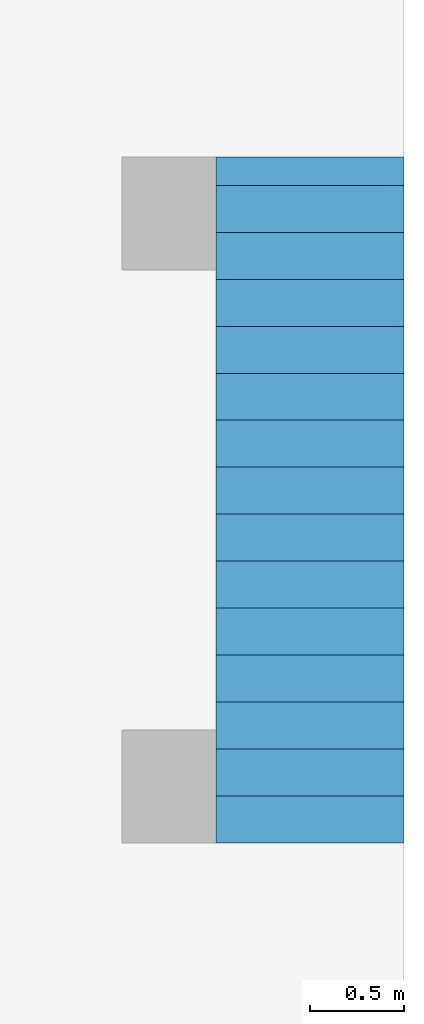
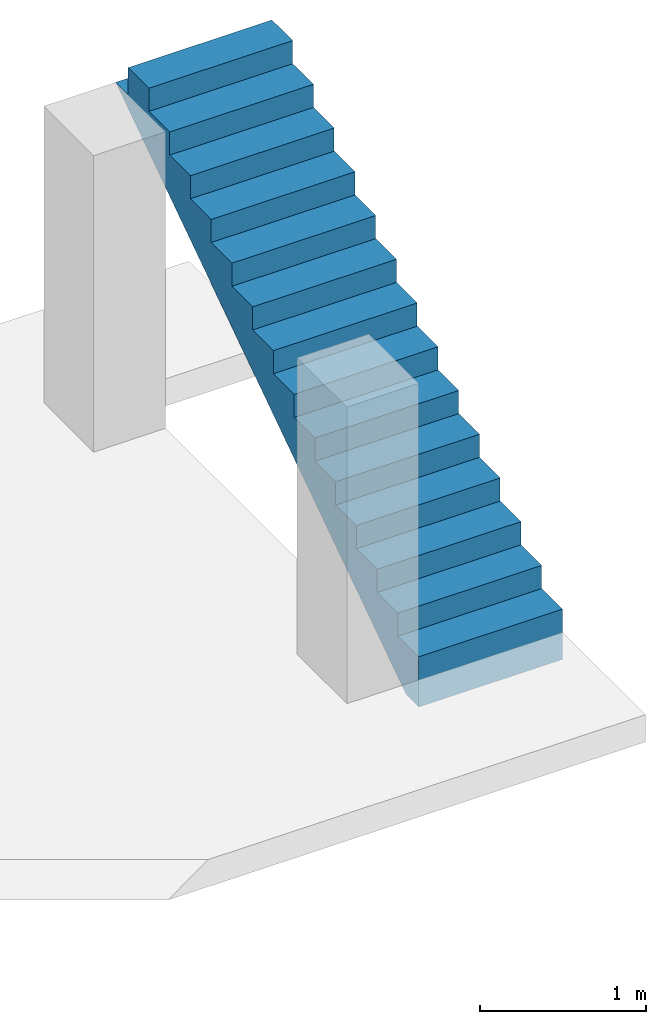
# One storey, part 2 of 2: 1 stair flight.
"""IFC4 building model written with IfcOpenShell, lengths in millimetres."""

from ifc_helpers import new_model, entity, si_unit, converted_unit, frame, origin_with_axes, origin_2d_with_axis, place, context, subcontext, project, spatial, polygons, element, save


model = new_model("IFC4")

# Units and contexts
model_context = context("Model", 3, precision=1e-05, world=origin_with_axes())
plan_context = context("Plan", 2, precision=1e-05, world=origin_2d_with_axis())
body_context = subcontext(model_context, "Body", "Model", "MODEL_VIEW")
ifc_project = project(units=[si_unit("VOLUMEUNIT", "CUBIC_METRE", prefix="MILLI"), si_unit("LENGTHUNIT", "METRE", prefix="MILLI"), converted_unit("PLANEANGLEUNIT", "degree", entity("IfcReal", 0.0174532925199433), si_unit("PLANEANGLEUNIT", "RADIAN"), dimensions=[0, 0, 0, 0, 0, 0, 0]), si_unit("AREAUNIT", "SQUARE_METRE", prefix="MILLI")], contexts=[model_context, plan_context])

# Site, building, storey
site_placement = place(None, origin_with_axes())
site = spatial("IfcSite", under=ifc_project, at=site_placement)
building_placement = place(site_placement, origin_with_axes())
building = spatial("IfcBuilding", under=site, at=building_placement, Name="Building")
storey_placement = place(building_placement, frame((0.0, 0.0, 2380.00011444092), z_axis=(0.0, 0.0, 1.0), x_axis=(1.0, 0.0, 0.0)))
storey = spatial("IfcBuildingStorey", under=building, at=storey_placement, Name="1st Floor")

# Stair flight
stair_flight_placement = place(storey_placement, frame((5000.0, 1000.0, 0.0), z_axis=(0.0, 0.0, 1.0), x_axis=(-4.37113882867379e-08, 1.0, 0.0)))
element("IfcStairFlight", 1, at=stair_flight_placement, inside=storey, Name="Stair", NumberOfRisers=7, NumberOfTreads=6, PredefinedType="STRAIGHT", RiserHeight=142.857142857143, TreadLength=250.0, context=body_context, shape_type="Tessellation", body=[
    polygons([(0.0, 0.0, 0.0), (0.0, 0.0, 169.999984741211), (249.999984741211, 0.0, 169.999984741211), (249.999984741211, 0.0, 339.999969482422), (499.999969482422, 0.0, 339.999969482422), (499.999969482422, 0.0, 509.999969482422), (749.999938964844, 0.0, 509.999969482422), (749.999938964844, 0.0, 679.999938964844), (999.999938964844, 0.0, 679.999938964844), (999.999938964844, 0.0, 850.0), (1249.99987792969, 0.0, 850.0), (1249.99987792969, 0.0, 1019.99993896484), (1499.99987792969, 0.0, 1019.99993896484), (1499.99987792969, 0.0, 1190.0), (1749.99987792969, 0.0, 1190.0), (1749.99987792969, 0.0, 1359.99987792969), (1999.99987792969, 0.0, 1359.99987792969), (1999.99987792969, 0.0, 1529.99987792969), (2249.99975585938, 0.0, 1529.99987792969), (2249.99975585938, 0.0, 1700.0), (2499.99975585938, 0.0, 1700.0), (2499.99975585938, 0.0, 1869.99987792969), (2749.99975585938, 0.0, 1869.99987792969), (2749.99975585938, 0.0, 2039.99987792969), (2999.99975585938, 0.0, 2039.99987792969), (2999.99975585938, 0.0, 2210.0), (3249.99975585938, 0.0, 2210.0), (3249.99975585938, 0.0, 2380.0), (3499.99975585938, 0.0, 2380.0), (3499.99975585938, 0.0, 2180.0), (3650.47680664062, 0.0, 2180.0), (150.476959228516, 0.0, -199.999984741211), (0.0, 0.0, -199.999984741211), (0.0, 999.999938964844, 169.999984741211), (249.999984741211, 999.999938964844, 169.999984741211), (249.999984741211, 999.999938964844, 339.999969482422), (499.999969482422, 999.999938964844, 339.999969482422), (499.999969482422, 999.999938964844, 509.999969482422), (749.999938964844, 999.999938964844, 509.999969482422), (749.999938964844, 999.999938964844, 679.999938964844), (999.999938964844, 999.999938964844, 679.999938964844), (999.999938964844, 999.999938964844, 850.0), (1249.99987792969, 999.999938964844, 850.0), (1249.99987792969, 999.999938964844, 1019.99993896484), (1499.99987792969, 999.999938964844, 1019.99993896484), (1499.99987792969, 999.999938964844, 1190.0), (1749.99987792969, 999.999938964844, 1190.0), (1749.99987792969, 999.999938964844, 1359.99987792969), (1999.99987792969, 999.999938964844, 1359.99987792969), (1999.99987792969, 999.999938964844, 1529.99987792969), (2249.99975585938, 999.999938964844, 1529.99987792969), (2249.99975585938, 999.999938964844, 1700.0), (2499.99975585938, 999.999938964844, 1700.0), (2499.99975585938, 999.999938964844, 1869.99987792969), (2749.99975585938, 999.999938964844, 1869.99987792969), (2749.99975585938, 999.999938964844, 2039.99987792969), (2999.99975585938, 999.999938964844, 2039.99987792969), (2999.99975585938, 999.999938964844, 2210.0), (3249.99975585938, 999.999938964844, 2210.0), (3249.99975585938, 999.999938964844, 2380.0), (3499.99975585938, 999.999938964844, 2380.0), (3499.99975585938, 999.999938964844, 2180.0), (3650.47680664062, 999.999938964844, 2180.0), (150.476959228516, 999.999938964844, -199.999984741211), (0.0, 999.999938964844, -199.999984741211), (0.0, 999.999938964844, 0.0)], [[[2, 1, 33, 32, 31, 30, 29, 28, 27, 26, 25, 24, 23, 22, 21, 20, 19, 18, 17, 16, 15, 14, 13, 12, 11, 10, 9, 8, 7, 6, 5, 4, 3]], [[34, 35, 36, 37, 38, 39, 40, 41, 42, 43, 44, 45, 46, 47, 48, 49, 50, 51, 52, 53, 54, 55, 56, 57, 58, 59, 60, 61, 62, 63, 64, 65, 66]], [[21, 22, 54, 53]], [[8, 9, 41, 40]], [[22, 23, 55, 54]], [[9, 10, 42, 41]], [[23, 24, 56, 55]], [[10, 11, 43, 42]], [[24, 25, 57, 56]], [[11, 12, 44, 43]], [[25, 26, 58, 57]], [[12, 13, 45, 44]], [[26, 27, 59, 58]], [[13, 14, 46, 45]], [[27, 28, 60, 59]], [[14, 15, 47, 46]], [[1, 2, 34, 66]], [[28, 29, 61, 60]], [[15, 16, 48, 47]], [[2, 3, 35, 34]], [[29, 30, 62, 61]], [[16, 17, 49, 48]], [[3, 4, 36, 35]], [[30, 31, 63, 62]], [[17, 18, 50, 49]], [[4, 5, 37, 36]], [[33, 1, 66, 65]], [[18, 19, 51, 50]], [[5, 6, 38, 37]], [[32, 33, 65, 64]], [[19, 20, 52, 51]], [[6, 7, 39, 38]], [[31, 32, 64, 63]], [[20, 21, 53, 52]], [[7, 8, 40, 39]]]),
])

save(model, "model.ifc")
